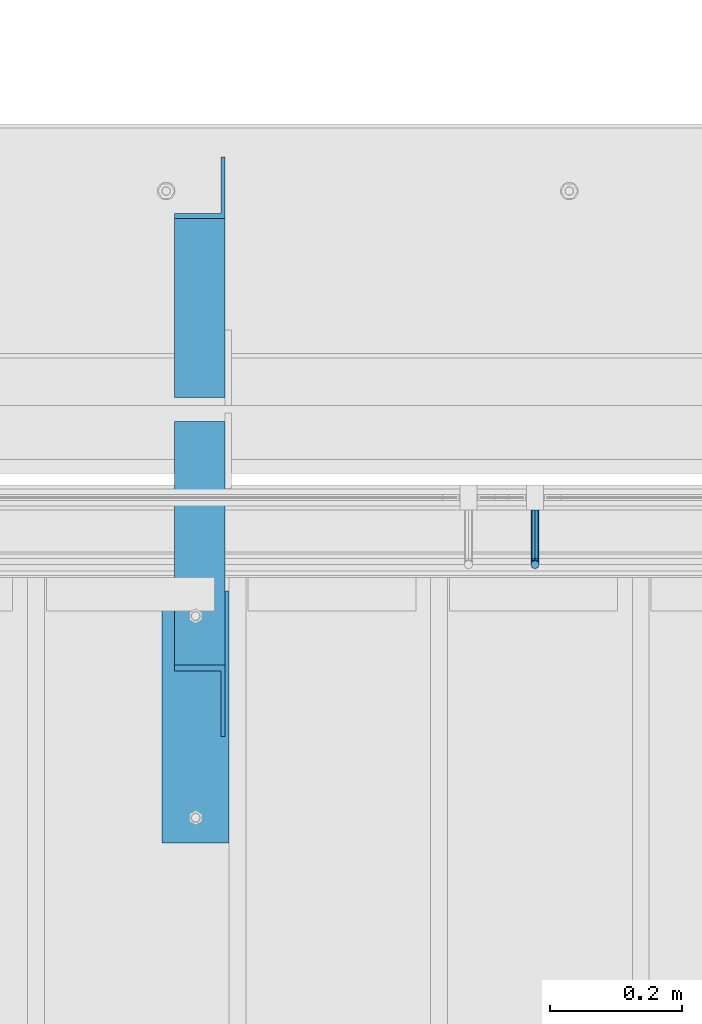
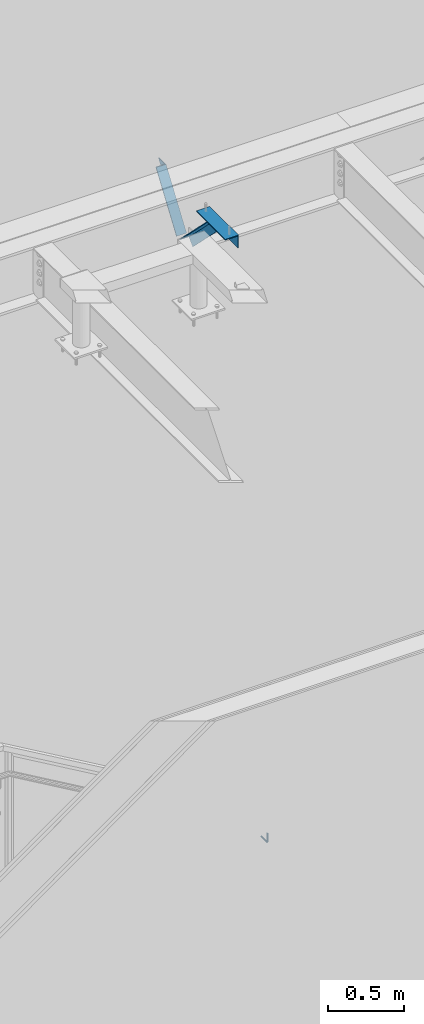
# One storey, part 944 of 1179: 2 beams, 2 members, 4 elements without a shape of their own.
"""IFC2X3 building model written with IfcOpenShell, lengths in millimetres."""

from ifc_helpers import new_model, si_unit, frame, origin_with_axes, place, context, subcontext, project, spatial, faceted_brep, material, type_object, element, aggregate, save


model = new_model("IFC2X3")

# Units and contexts
model_context = context("Model", 3, precision=1e-05, world=origin_with_axes())
body_context = subcontext(model_context, "Body", "Model", "MODEL_VIEW")
ifc_project = project(units=[si_unit("LENGTHUNIT", "METRE", prefix="MILLI"), si_unit("AREAUNIT", "SQUARE_METRE"), si_unit("VOLUMEUNIT", "CUBIC_METRE"), si_unit("MASSUNIT", "GRAM", prefix="KILO"), si_unit("TIMEUNIT", "SECOND"), si_unit("PLANEANGLEUNIT", "RADIAN"), si_unit("SOLIDANGLEUNIT", "STERADIAN"), si_unit("THERMODYNAMICTEMPERATUREUNIT", "DEGREE_CELSIUS"), si_unit("LUMINOUSINTENSITYUNIT", "LUMEN")], contexts=[model_context])

# Site, building, storey
site_placement = place(None, origin_with_axes())
site = spatial("IfcSite", under=ifc_project, at=site_placement, CompositionType="ELEMENT")
building_placement = place(site_placement, origin_with_axes())
building = spatial("IfcBuilding", under=site, at=building_placement, Name="Undefined", CompositionType="ELEMENT")
storey_placement = place(building_placement, origin_with_axes())
storey = spatial("IfcBuildingStorey", under=building, at=storey_placement, Name="Undefined", CompositionType="ELEMENT", Elevation=0.0)

# Assembly, beam
assembly_1_placement = place(storey_placement, origin_with_axes())
assembly_1 = element("IfcElementAssembly", 1, at=assembly_1_placement, inside=storey, Name="GUARDRAIL", AssemblyPlace="NOTDEFINED", PredefinedType="RIGID_FRAME")
ifc_material = material(Name="STEEL/A36")
beam_type_1 = type_object("IfcBeamType", PredefinedType="NOTDEFINED")
beam_1_placement = place(assembly_1_placement, frame((21766.7416677562, 41046.3999992247, 7819.26715148999), z_axis=(0.0, 0.0, 1.0), x_axis=(0.0, -1.0, 0.0)))
beam_1 = element("IfcBeam", 2, at=beam_1_placement, type_object=beam_type_1, material=ifc_material, Name="BRACKET", context=body_context, shape_type="Brep", body=[
    faceted_brep([(0.0, -4.49012806053361, 4.49012806053452), (0.0, 0.0, 6.34999999999991), (0.0, 4.49012806053361, 4.49012806053452), (0.0, 6.34999999999854, 0.0), (0.0, 4.49012806053361, -4.49012806053452), (0.0, 0.0, -6.34999999999991), (0.0, -4.49012806053361, -4.49012806053452), (0.0, -6.34999999999854, 0.0), (69.849999425729, 0.0, -6.34999999999991), (69.849999425729, -4.49012806053361, -4.49012806053452), (69.849999425729, -6.34999999999854, 0.0), (69.849999425729, -4.49012806053361, 4.49012806053452), (69.849999425729, 0.0, 6.34999999999991), (69.849999425729, 4.49012806053361, 4.49012806053452), (69.849999425729, 6.34999999999854, 0.0), (69.849999425729, 4.49012806053361, -4.49012806053452), (78.445063360632, 4.49012806053361, -2.18708762028064), (79.3749993303718, 0.0, -3.79778396764323), (78.445063360632, -4.49012806053361, -2.18708762028064), (76.1999993303689, -6.34999999999854, 1.70147734638658), (73.9549353000984, -4.49012806053361, 5.59004231305425), (73.024999330366, 0.0, 7.20073866041639), (73.9549353000984, 4.49012806053361, 5.59004231305425), (76.1999993303689, 6.34999999999854, 1.70147734638658), (80.8485218886053, 6.34999999999854, 6.34999990462893), (84.7370868552753, 4.49012806053361, 4.10493587436031), (76.9599569219426, 4.49012806053361, 8.59506393489755), (75.3492605745778, 0.0, 9.52499990463093), (76.9599569219426, -4.49012806053361, 8.59506393489755), (80.8485218886053, -6.34999999999854, 6.34999990462893), (84.7370868552753, -4.49012806053361, 4.10493587436031), (86.3477832026401, 0.0, 3.17499990462693), (87.0401272955278, 4.49012806053361, 12.6999998092651), (88.8999992349927, 0.0, 12.6999998092651), (82.5499992349942, 6.34999999999854, 12.6999998092651), (78.0598711744606, 4.49012806053361, 12.6999998092651), (76.1999992349956, 0.0, 12.6999998092651), (78.0598711744606, -4.49012806053361, 12.6999998092651), (82.5499992349942, -6.34999999999854, 12.6999998092651), (87.0401272955278, -4.49012806053361, 12.6999998092651), (88.8999992349927, 0.0, 76.2000000000003), (87.0401272908275, -4.49012806053361, 78.7997529672102), (82.5499992302939, -6.34999999999854, 79.8766059046975), (78.0598711697603, -4.49012806053361, 78.7997529672102), (76.1999992349956, 0.0, 76.2000000000003), (78.0598711697603, 4.49012806053361, 73.6002470344774), (82.5499992302939, 6.34999999999854, 72.5233940969902), (87.0401272908275, 4.49012806053361, 73.6002470344774)], [[[0, 1, 2, 3, 4, 5, 6, 7]], [[6, 5, 8, 9]], [[7, 6, 9, 10]], [[0, 7, 10, 11]], [[1, 0, 11, 12]], [[2, 1, 12, 13]], [[3, 2, 13, 14]], [[4, 3, 14, 15]], [[5, 4, 15, 8]], [[8, 15, 16, 17]], [[9, 8, 17, 18]], [[10, 9, 18, 19]], [[11, 10, 19, 20]], [[12, 11, 20, 21]], [[13, 12, 21, 22]], [[14, 13, 22, 23]], [[15, 14, 23, 16]], [[23, 24, 25, 16]], [[22, 26, 24, 23]], [[21, 27, 26, 22]], [[20, 28, 27, 21]], [[19, 29, 28, 20]], [[18, 30, 29, 19]], [[17, 31, 30, 18]], [[16, 25, 31, 17]], [[25, 32, 33, 31]], [[24, 34, 32, 25]], [[26, 35, 34, 24]], [[27, 36, 35, 26]], [[28, 37, 36, 27]], [[29, 38, 37, 28]], [[30, 39, 38, 29]], [[31, 33, 39, 30]], [[39, 33, 40, 41]], [[38, 39, 41, 42]], [[37, 38, 42, 43]], [[36, 37, 43, 44]], [[35, 36, 44, 45]], [[34, 35, 45, 46]], [[32, 34, 46, 47]], [[33, 32, 47, 40]], [[46, 45, 44, 43, 42, 41, 40, 47]]]),
])
aggregate(assembly_1, [beam_1])

# Assembly, member
assembly_2_placement = place(storey_placement, origin_with_axes())
assembly_2 = element("IfcElementAssembly", 3, at=assembly_2_placement, inside=storey, Name="ANGLE", AssemblyPlace="NOTDEFINED", PredefinedType="RIGID_FRAME")
member_type = type_object("IfcMemberType", Name="L3X3X1/4", PredefinedType="NOTDEFINED")
member_1_placement = place(assembly_2_placement, frame((21259.8, 40704.7386537875, 13150.1502196524), z_axis=(0.0, -0.706388288025418, -0.707824545025474), x_axis=(0.0, 0.707824545025473, -0.706388288025419)))
member_1 = element("IfcMember", 4, at=member_1_placement, type_object=member_type, material=ifc_material, Name="ANGLE", ObjectType="L3X3X1/4", context=body_context, shape_type="Brep", body=[
    faceted_brep([(634.184990526992, 31.75, 38.0999999999767), (634.184990526996, 31.75, -31.7499999999636), (634.184990526996, -38.0999999999985, -31.7499999999636), (634.184990526996, -38.0999999999985, -38.0999999999549), (634.184990526996, 38.0999999999985, -38.0999999999549), (634.184990526992, 38.0999999999985, 38.0999999999767), (113.596638248473, -38.0999999999985, -38.0999999999549), (113.596638248473, 38.0999999999985, -38.0999999999549), (37.2417053522113, 38.0999999999985, 38.0999999999694), (37.2417053522113, 31.75, 38.0999999999694), (107.233727173789, 31.75, -31.7499999999709), (107.233727173789, -38.0999999999985, -31.7499999999709)], [[[0, 1, 2, 3, 4, 5]], [[4, 3, 6, 7]], [[5, 4, 7, 8]], [[0, 5, 8, 9]], [[1, 0, 9, 10]], [[2, 1, 10, 11]], [[3, 2, 11, 6]], [[10, 9, 8, 7, 6, 11]]]),
])
aggregate(assembly_2, [member_1])

assembly_3_placement = place(storey_placement, origin_with_axes())
assembly_3 = element("IfcElementAssembly", 5, at=assembly_3_placement, inside=storey, Name="ANGLE", AssemblyPlace="NOTDEFINED", PredefinedType="RIGID_FRAME")
member_2_placement = place(assembly_3_placement, frame((21259.8, 41248.3636551321, 12707.4244380128), z_axis=(0.0, 0.821716663099518, -0.569896241069015), x_axis=(0.0, 0.569896241069016, 0.821716663099518)))
member_2 = element("IfcMember", 6, at=member_2_placement, type_object=member_type, material=ifc_material, Name="ANGLE", ObjectType="L3X3X1/4", context=body_context, shape_type="Brep", body=[
    faceted_brep([(0.0, -38.0999999999985, -38.0999999999999), (0.0, -38.0999999999985, -31.75), (0.0, 31.75, -31.75), (0.0, 31.75, 38.1000000000004), (0.0, 38.0999999999985, 38.0999999999999), (0.0, 38.0999999999985, -38.0999999999999), (527.418547333735, 31.75, 38.0999999993364), (527.418547333735, 38.1000000000004, 38.0999999993364), (474.570533511644, 38.1000000000004, -38.1000000006607), (474.570533511644, -38.1000000000004, -38.1000000006607), (478.974534663488, -38.1000000000004, -31.7500000006621), (478.974534663488, 31.75, -31.7500000006621)], [[[0, 1, 2, 3, 4, 5]], [[4, 3, 6, 7]], [[5, 4, 7, 8]], [[0, 5, 8, 9]], [[1, 0, 9, 10]], [[2, 1, 10, 11]], [[3, 2, 11, 6]], [[10, 9, 8, 7, 6, 11]]]),
])
aggregate(assembly_3, [member_2])

# Assembly, beam
assembly_4_placement = place(storey_placement, origin_with_axes())
assembly_4 = element("IfcElementAssembly", 7, at=assembly_4_placement, inside=storey, Name="ANGLE", AssemblyPlace="NOTDEFINED", PredefinedType="RIGID_FRAME")
beam_type_2 = type_object("IfcBeamType", Name="L4X4X1/4", PredefinedType="NOTDEFINED")
beam_2_placement = place(assembly_4_placement, frame((21253.449999998, 40924.162499953, 13068.3), z_axis=(-1.0, 0.0, 0.0), x_axis=(0.0, -1.0, 0.0)))
beam_2 = element("IfcBeam", 8, at=beam_2_placement, type_object=beam_type_2, material=ifc_material, Name="ANGLE", ObjectType="L4X4X1/4", context=body_context, shape_type="Brep", body=[
    faceted_brep([(1.90993887372315e-11, 50.8000000000002, -50.8000000000002), (1.90993887372315e-11, 50.8000000000002, 50.8000000000002), (381.0, 50.8000000000002, 50.7999999999993), (381.0, 50.8000000000002, -50.7999999999993), (0.0, 44.4500000000007, 50.8000000000002), (381.0, 44.4499999999998, 50.7999999999993), (0.0, 44.4500000000007, -44.4499999999998), (381.0, 44.4499999999998, -44.4500000000007), (0.0, -50.7999999999993, -44.4499999999998), (381.0, -50.8000000000002, -44.4500000000007), (-1.81898940354586e-11, -50.7999999999997, -50.8000000000002), (381.0, -50.8000000000002, -50.7999999999993)], [[[0, 1, 2, 3]], [[1, 4, 5, 2]], [[4, 6, 7, 5]], [[6, 8, 9, 7]], [[8, 10, 11, 9]], [[10, 0, 3, 11]], [[5, 7, 9, 11, 3, 2]], [[10, 8, 6, 4, 1, 0]]]),
])
aggregate(assembly_4, [beam_2])

save(model, "model.ifc")
